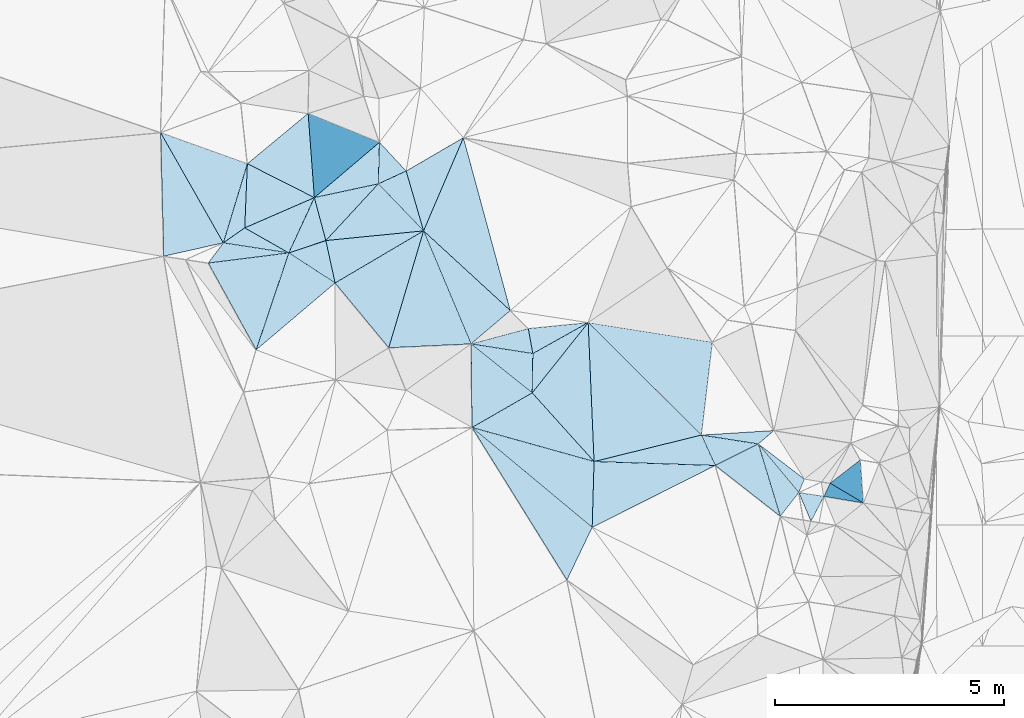
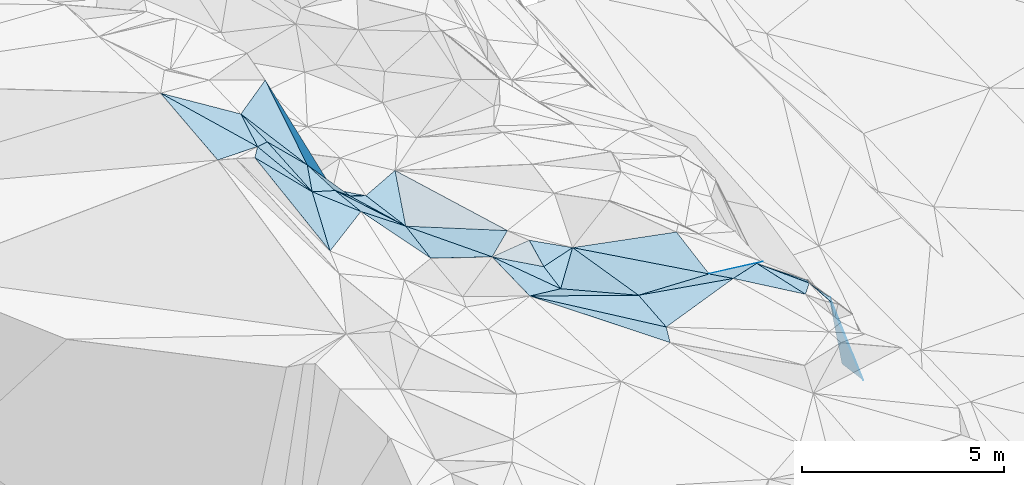
# One storey, part 132 of 275: 45 plates.
"""IFC2X3 building model written with IfcOpenShell, lengths in millimetres."""

from ifc_helpers import new_model, si_unit, frame, origin_with_axes, place, context, subcontext, project, spatial, polyline, outline, extrude, material, type_object, element, save


model = new_model("IFC2X3")

# Units and contexts
model_context = context("Model", 3, precision=1e-05, world=origin_with_axes())
body_context = subcontext(model_context, "Body", "Model", "MODEL_VIEW")
ifc_project = project(units=[si_unit("LENGTHUNIT", "METRE", prefix="MILLI"), si_unit("AREAUNIT", "SQUARE_METRE"), si_unit("VOLUMEUNIT", "CUBIC_METRE"), si_unit("MASSUNIT", "GRAM", prefix="KILO"), si_unit("TIMEUNIT", "SECOND"), si_unit("PLANEANGLEUNIT", "RADIAN"), si_unit("SOLIDANGLEUNIT", "STERADIAN"), si_unit("THERMODYNAMICTEMPERATUREUNIT", "DEGREE_CELSIUS"), si_unit("LUMINOUSINTENSITYUNIT", "LUMEN")], contexts=[model_context])

# Site, building, storey
site_placement = place(None, origin_with_axes())
site = spatial("IfcSite", under=ifc_project, at=site_placement, CompositionType="ELEMENT")
building_placement = place(site_placement, origin_with_axes())
building = spatial("IfcBuilding", under=site, at=building_placement, Name="Undefined", CompositionType="ELEMENT")
storey_placement = place(building_placement, origin_with_axes())
storey = spatial("IfcBuildingStorey", under=building, at=storey_placement, Name="Undefined", CompositionType="ELEMENT", Elevation=0.0)

# Plates
ifc_material = material()
plate_type_1 = type_object("IfcPlateType", PredefinedType="NOTDEFINED")
plate_1_placement = place(storey_placement, frame((-101077.108346665, 115262.786715546, 51369.5086691945), z_axis=(-0.182962284867591, 0.031444038574447, -0.982616952201701), x_axis=(-0.777096045290912, 0.607602228852694, 0.164137953826845)))
element("IfcPlate", 1, at=plate_1_placement, inside=storey, type_object=plate_type_1, material=ifc_material, Name="00", context=body_context, shape_type="SweptSolid", body=[
    extrude(outline(polyline([(0.0, 0.0), (1827.73083496094, 7.90896592661738e-09), (1356.65490722656, 953.2509765625), (0.0, 0.0)])), frame((-8.85201319254618e-08, 2.18876761149539e-07, -0.5000001331573), z_axis=(0.0, 0.0, 1.0), x_axis=(1.0, 0.0, 0.0)), (0.0, 0.0, 1.0), 1.0),
])
plate_type_2 = type_object("IfcPlateType", PredefinedType="NOTDEFINED")
plate_2_placement = place(storey_placement, frame((-107838.171604734, 119030.818476236, 52579.5627187452), z_axis=(-0.483887104262502, 0.0327773503198025, -0.874516389574525), x_axis=(0.710391993336381, -0.568875633902452, -0.414395618890508)))
element("IfcPlate", 2, at=plate_2_placement, inside=storey, type_object=plate_type_2, material=ifc_material, Name="00", context=body_context, shape_type="SweptSolid", body=[
    extrude(outline(polyline([(0.0, 0.0), (1882.25927734375, -1.17724994197488e-08), (1087.62915039063, 1471.14343261719), (0.0, 0.0)])), frame((-8.85201319254618e-08, 2.18876761149539e-07, -0.5000001331573), z_axis=(0.0, 0.0, 1.0), x_axis=(1.0, 0.0, 0.0)), (0.0, 0.0, 1.0), 1.0),
])
plate_type_3 = type_object("IfcPlateType", PredefinedType="NOTDEFINED")
plate_3_placement = place(storey_placement, frame((-111012.926565, 121290.092607468, 54319.6722247281), z_axis=(-0.755192114331639, 0.000595253950786495, -0.655503254091116), x_axis=(-0.247513106414454, 0.925712610213253, 0.285995498994711)))
element("IfcPlate", 3, at=plate_3_placement, inside=storey, type_object=plate_type_3, material=ifc_material, Name="00", context=body_context, shape_type="SweptSolid", body=[
    extrude(outline(polyline([(0.0, 0.0), (1014.001953125, -4.00177668780088e-09), (486.093719482422, 2087.46557617188), (0.0, 0.0)])), frame((-8.85201319254618e-08, 2.18876761149539e-07, -0.5000001331573), z_axis=(0.0, 0.0, 1.0), x_axis=(1.0, 0.0, 0.0)), (0.0, 0.0, 1.0), 1.0),
])
plate_type_4 = type_object("IfcPlateType", PredefinedType="NOTDEFINED")
plate_4_placement = place(storey_placement, frame((-109840.872069858, 123437.121596076, 52649.5663538302), z_axis=(-0.378087920472236, -0.323940930708108, -0.867243793754066), x_axis=(0.68078087842298, -0.732115498970907, -0.023330060870378)))
element("IfcPlate", 4, at=plate_4_placement, inside=storey, type_object=plate_type_4, material=ifc_material, Name="00", context=body_context, shape_type="SweptSolid", body=[
    extrude(outline(polyline([(0.0, 0.0), (857.263061523438, -2.80988388112746e-09), (639.24365234375, 733.7353515625), (0.0, 0.0)])), frame((-8.85201319254618e-08, 2.18876761149539e-07, -0.5000001331573), z_axis=(0.0, 0.0, 1.0), x_axis=(1.0, 0.0, 0.0)), (0.0, 0.0, 1.0), 1.0),
])
plate_type_5 = type_object("IfcPlateType", PredefinedType="NOTDEFINED")
plate_5_placement = place(storey_placement, frame((-102497.358780842, 116373.178783686, 51669.5163870019), z_axis=(-0.0390057522688102, -0.251076131078174, -0.967181124553597), x_axis=(-0.407169839184442, 0.887909828823298, -0.214076757116452)))
element("IfcPlate", 5, at=plate_5_placement, inside=storey, type_object=plate_type_5, material=ifc_material, Name="00", context=body_context, shape_type="SweptSolid", body=[
    extrude(outline(polyline([(0.0, 0.0), (747.3955078125, 3.07773007079959e-09), (69.0397567749023, 1061.05297851563), (0.0, 0.0)])), frame((-8.85201319254618e-08, 2.18876761149539e-07, -0.5000001331573), z_axis=(0.0, 0.0, 1.0), x_axis=(1.0, 0.0, 0.0)), (0.0, 0.0, 1.0), 1.0),
])
plate_type_6 = type_object("IfcPlateType", PredefinedType="NOTDEFINED")
plate_6_placement = place(storey_placement, frame((-108875.928222618, 121502.237612127, 52369.5129660473), z_axis=(-0.176136638375276, 0.142329663975436, -0.974021638042244), x_axis=(-0.274953401369409, 0.942994209059172, 0.187516795931085)))
element("IfcPlate", 6, at=plate_6_placement, inside=storey, type_object=plate_type_6, material=ifc_material, Name="00", context=body_context, shape_type="SweptSolid", body=[
    extrude(outline(polyline([(0.0, 0.0), (1386.54248046875, -7.97444954514503e-09), (1706.76342773438, 1418.11791992188), (0.0, 0.0)])), frame((-8.85201319254618e-08, 2.18876761149539e-07, -0.5000001331573), z_axis=(0.0, 0.0, 1.0), x_axis=(1.0, 0.0, 0.0)), (0.0, 0.0, 1.0), 1.0),
])
plate_type_7 = type_object("IfcPlateType", PredefinedType="NOTDEFINED")
plate_7_placement = place(storey_placement, frame((-99259.4544158004, 115552.595926129, 47959.8654283278), z_axis=(-0.959563111316431, -0.0826057911588249, -0.269100201909539), x_axis=(-0.279513631256925, 0.166423466974687, 0.945608459977856)))
element("IfcPlate", 7, at=plate_7_placement, inside=storey, type_object=plate_type_7, material=ifc_material, Name="00", context=body_context, shape_type="SweptSolid", body=[
    extrude(outline(polyline([(0.0, 0.0), (2601.49951171875, 7.15954229235649e-09), (128.502807617188, 938.342712402344), (0.0, 0.0)])), frame((-8.85201319254618e-08, 2.18876761149539e-07, -0.5000001331573), z_axis=(0.0, 0.0, 1.0), x_axis=(1.0, 0.0, 0.0)), (0.0, 0.0, 1.0), 1.0),
])
plate_type_8 = type_object("IfcPlateType", PredefinedType="NOTDEFINED")
plate_8_placement = place(storey_placement, frame((-108876.102537069, 121502.174567281, 52369.5744315217), z_axis=(-0.524768448998923, 0.0162321718583535, -0.851090237008994), x_axis=(-0.634731658565593, 0.658754098098725, 0.403929152021375)))
element("IfcPlate", 8, at=plate_8_placement, inside=storey, type_object=plate_type_8, material=ifc_material, Name="00", context=body_context, shape_type="SweptSolid", body=[
    extrude(outline(polyline([(0.0, 0.0), (1559.67944335938, 6.81393430568278e-09), (1208.3251953125, 680.036926269531), (0.0, 0.0)])), frame((-8.85201319254618e-08, 2.18876761149539e-07, -0.5000001331573), z_axis=(0.0, 0.0, 1.0), x_axis=(1.0, 0.0, 0.0)), (0.0, 0.0, 1.0), 1.0),
])
plate_type_9 = type_object("IfcPlateType", PredefinedType="NOTDEFINED")
plate_9_placement = place(storey_placement, frame((-111263.953019028, 122228.912316033, 54609.7810191982), z_axis=(-0.850555645167409, 0.291181920721333, -0.43791344295293), x_axis=(-0.0575177623576094, 0.77621183591715, 0.627843047899315)))
element("IfcPlate", 9, at=plate_9_placement, inside=storey, type_object=plate_type_9, material=ifc_material, Name="00", context=body_context, shape_type="SweptSolid", body=[
    extrude(outline(polyline([(0.0, 0.0), (2373.20458984375, -5.17320586368442e-09), (-374.346160888672, 2680.75830078125), (0.0, 0.0)])), frame((-8.85201319254618e-08, 2.18876761149539e-07, -0.5000001331573), z_axis=(0.0, 0.0, 1.0), x_axis=(1.0, 0.0, 0.0)), (0.0, 0.0, 1.0), 1.0),
])
plate_type_10 = type_object("IfcPlateType", PredefinedType="NOTDEFINED")
plate_10_placement = place(storey_placement, frame((-111263.769573413, 122228.835583972, 54609.5677979019), z_axis=(-0.483651953007309, 0.137723123119735, -0.864357061468443), x_axis=(0.247513106421055, -0.925712610211206, -0.285995498995624)))
element("IfcPlate", 10, at=plate_10_placement, inside=storey, type_object=plate_type_10, material=ifc_material, Name="00", context=body_context, shape_type="SweptSolid", body=[
    extrude(outline(polyline([(0.0, 0.0), (1014.001953125, -4.00177668780088e-09), (946.743713378906, 944.709655761719), (0.0, 0.0)])), frame((-8.85201319254618e-08, 2.18876761149539e-07, -0.5000001331573), z_axis=(0.0, 0.0, 1.0), x_axis=(1.0, 0.0, 0.0)), (0.0, 0.0, 1.0), 1.0),
])
plate_type_11 = type_object("IfcPlateType", PredefinedType="NOTDEFINED")
plate_11_placement = place(storey_placement, frame((-111822.486857944, 121019.681198865, 54729.5450177041), z_axis=(-0.348634186114581, 0.224736675516416, -0.909916276890381), x_axis=(0.763235014934355, -0.495400192584353, -0.41479026165707)))
element("IfcPlate", 11, at=plate_11_placement, inside=storey, type_object=plate_type_11, material=ifc_material, Name="00", context=body_context, shape_type="SweptSolid", body=[
    extrude(outline(polyline([(0.0, 0.0), (1325.97131347656, -2.99769453704357e-09), (608.912109375, 2166.63940429688), (0.0, 0.0)])), frame((-8.85201319254618e-08, 2.18876761149539e-07, -0.5000001331573), z_axis=(0.0, 0.0, 1.0), x_axis=(1.0, 0.0, 0.0)), (0.0, 0.0, 1.0), 1.0),
])
plate_type_12 = type_object("IfcPlateType", PredefinedType="NOTDEFINED")
plate_12_placement = place(storey_placement, frame((-99986.5974080244, 115985.673115825, 50419.8465753162), z_axis=(-0.936355367715108, 0.170613160853396, -0.306805760530533), x_axis=(0.279513631268442, -0.166423466966174, -0.94560845997595)))
element("IfcPlate", 12, at=plate_12_placement, inside=storey, type_object=plate_type_12, material=ifc_material, Name="00", context=body_context, shape_type="SweptSolid", body=[
    extrude(outline(polyline([(0.0, 0.0), (2601.49951171875, 7.15954229235649e-09), (-225.908172607422, 336.400787353516), (0.0, 0.0)])), frame((-8.85201319254618e-08, 2.18876761149539e-07, -0.5000001331573), z_axis=(0.0, 0.0, 1.0), x_axis=(1.0, 0.0, 0.0)), (0.0, 0.0, 1.0), 1.0),
])
plate_type_13 = type_object("IfcPlateType", PredefinedType="NOTDEFINED")
plate_13_placement = place(storey_placement, frame((-101216.547858828, 117136.070342253, 51259.5964902693), z_axis=(-0.0906622442212895, -0.583583804214639, -0.806976022525533), x_axis=(-0.662741964870865, -0.569472900091666, 0.486285619837039)))
element("IfcPlate", 13, at=plate_13_placement, inside=storey, type_object=plate_type_13, material=ifc_material, Name="00", context=body_context, shape_type="SweptSolid", body=[
    extrude(outline(polyline([(0.0, 0.0), (514.101135253906, 1.93540472537279e-09), (1228.74645996094, 1036.9580078125), (0.0, 0.0)])), frame((-8.85201319254618e-08, 2.18876761149539e-07, -0.5000001331573), z_axis=(0.0, 0.0, 1.0), x_axis=(1.0, 0.0, 0.0)), (0.0, 0.0, 1.0), 1.0),
])
plate_type_14 = type_object("IfcPlateType", PredefinedType="NOTDEFINED")
plate_14_placement = place(storey_placement, frame((-109841.038873697, 123437.165809717, 52649.6690516666), z_axis=(-0.711683980102566, -0.235502547208102, -0.661849274928867), x_axis=(-0.0258288257508461, -0.932725581802169, 0.359660757954129)))
element("IfcPlate", 14, at=plate_14_placement, inside=storey, type_object=plate_type_14, material=ifc_material, Name="00", context=body_context, shape_type="SweptSolid", body=[
    extrude(outline(polyline([(0.0, 0.0), (973.139221191406, -5.70435076951981e-09), (1868.90002441406, 1958.01245117188), (0.0, 0.0)])), frame((-8.85201319254618e-08, 2.18876761149539e-07, -0.5000001331573), z_axis=(0.0, 0.0, 1.0), x_axis=(1.0, 0.0, 0.0)), (0.0, 0.0, 1.0), 1.0),
])
plate_type_15 = type_object("IfcPlateType", PredefinedType="NOTDEFINED")
plate_15_placement = place(storey_placement, frame((-110810.514957261, 120362.699129017, 54179.5564247159), z_axis=(-0.460354447754996, 0.0335138894185833, -0.88710236255363), x_axis=(-0.763235014935772, 0.495400192582214, 0.414790261657018)))
element("IfcPlate", 15, at=plate_15_placement, inside=storey, type_object=plate_type_15, material=ifc_material, Name="00", context=body_context, shape_type="SweptSolid", body=[
    extrude(outline(polyline([(0.0, 0.0), (1325.97131347656, -2.99769453704357e-09), (671.884826660156, 684.96044921875), (0.0, 0.0)])), frame((-8.85201319254618e-08, 2.18876761149539e-07, -0.5000001331573), z_axis=(0.0, 0.0, 1.0), x_axis=(1.0, 0.0, 0.0)), (0.0, 0.0, 1.0), 1.0),
])
plate_16_placement = place(storey_placement, frame((-107838.131307046, 119030.878856185, 52579.5489235069), z_axis=(-0.403271693237357, 0.1535448908215, -0.902106372849726), x_axis=(0.894788751502755, -0.140286585797393, -0.423878241986365)))
element("IfcPlate", 16, at=plate_16_placement, inside=storey, type_object=plate_type_15, material=ifc_material, Name="00", context=body_context, shape_type="SweptSolid", body=[
    extrude(outline(polyline([(0.0, 0.0), (1509.86755371094, -5.5733835324645e-09), (1677.29943847656, 854.146667480469), (0.0, 0.0)])), frame((-8.85201319254618e-08, 2.18876761149539e-07, -0.5000001331573), z_axis=(0.0, 0.0, 1.0), x_axis=(1.0, 0.0, 0.0)), (0.0, 0.0, 1.0), 1.0),
])
plate_type_16 = type_object("IfcPlateType", PredefinedType="NOTDEFINED")
plate_17_placement = place(storey_placement, frame((-113253.855158895, 121239.878515028, 56459.6963707998), z_axis=(-0.667762325774241, 0.430568968177168, -0.607209881276174), x_axis=(0.634390816175151, -0.0975580018185462, -0.766831616871525)))
element("IfcPlate", 17, at=plate_17_placement, inside=storey, type_object=plate_type_16, material=ifc_material, Name="00", context=body_context, shape_type="SweptSolid", body=[
    extrude(outline(polyline([(0.0, 0.0), (2256.03637695313, -1.02445483207703e-08), (-204.562301635742, 513.764770507813), (0.0, 0.0)])), frame((-8.85201319254618e-08, 2.18876761149539e-07, -0.5000001331573), z_axis=(0.0, 0.0, 1.0), x_axis=(1.0, 0.0, 0.0)), (0.0, 0.0, 1.0), 1.0),
])
plate_type_17 = type_object("IfcPlateType", PredefinedType="NOTDEFINED")
plate_18_placement = place(storey_placement, frame((-102801.726887501, 117036.777690168, 51509.5271571889), z_axis=(-0.141424019289442, -0.292849055725468, -0.945641939281841), x_axis=(0.407169839185727, -0.887909828824076, 0.214076757110786)))
element("IfcPlate", 18, at=plate_18_placement, inside=storey, type_object=plate_type_17, material=ifc_material, Name="00", context=body_context, shape_type="SweptSolid", body=[
    extrude(outline(polyline([(0.0, 0.0), (747.3955078125, 3.07773007079959e-09), (-328.607818603516, 2452.2880859375), (0.0, 0.0)])), frame((-8.85201319254618e-08, 2.18876761149539e-07, -0.5000001331573), z_axis=(0.0, 0.0, 1.0), x_axis=(1.0, 0.0, 0.0)), (0.0, 0.0, 1.0), 1.0),
])
plate_type_18 = type_object("IfcPlateType", PredefinedType="NOTDEFINED")
plate_19_placement = place(storey_placement, frame((-111822.690205888, 121019.714208473, 54729.7063181024), z_axis=(-0.755326613196804, 0.290760610089798, -0.587315907341913), x_axis=(-0.514442984147752, 0.292129874820265, 0.806231078722876)))
element("IfcPlate", 19, at=plate_19_placement, inside=storey, type_object=plate_type_18, material=ifc_material, Name="00", context=body_context, shape_type="SweptSolid", body=[
    extrude(outline(polyline([(0.0, 0.0), (1872.91223144531, -7.48696038499475e-09), (-30.9678153991699, 1337.10168457031), (0.0, 0.0)])), frame((-8.85201319254618e-08, 2.18876761149539e-07, -0.5000001331573), z_axis=(0.0, 0.0, 1.0), x_axis=(1.0, 0.0, 0.0)), (0.0, 0.0, 1.0), 1.0),
])
plate_type_19 = type_object("IfcPlateType", PredefinedType="NOTDEFINED")
plate_20_placement = place(storey_placement, frame((-107838.054867006, 119031.116260068, 52579.6317113716), z_axis=(-0.250394181323223, 0.628351621189602, -0.736530375550033), x_axis=(0.960472364045447, 0.2568070213183, -0.107438315821557)))
element("IfcPlate", 20, at=plate_20_placement, inside=storey, type_object=plate_type_19, material=ifc_material, Name="00", context=body_context, shape_type="SweptSolid", body=[
    extrude(outline(polyline([(0.0, 0.0), (1303.0732421875, 9.22591425478458e-09), (1311.97534179688, 747.275573730469), (0.0, 0.0)])), frame((-8.85201319254618e-08, 2.18876761149539e-07, -0.5000001331573), z_axis=(0.0, 0.0, 1.0), x_axis=(1.0, 0.0, 0.0)), (0.0, 0.0, 1.0), 1.0),
])
plate_type_20 = type_object("IfcPlateType", PredefinedType="NOTDEFINED")
plate_21_placement = place(storey_placement, frame((-100672.253206617, 115780.82456089, 51249.6551102101), z_axis=(-0.723960092151855, 0.0121237250448085, -0.689735311741044), x_axis=(0.685064624005919, -0.104829660824563, -0.720900272677876)))
element("IfcPlate", 21, at=plate_21_placement, inside=storey, type_object=plate_type_20, material=ifc_material, Name="00", context=body_context, shape_type="SweptSolid", body=[
    extrude(outline(polyline([(0.0, 0.0), (804.549560546875, 4.40923031419516e-09), (456.777313232422, 581.338500976563), (0.0, 0.0)])), frame((-8.85201319254618e-08, 2.18876761149539e-07, -0.5000001331573), z_axis=(0.0, 0.0, 1.0), x_axis=(1.0, 0.0, 0.0)), (0.0, 0.0, 1.0), 1.0),
])
plate_type_21 = type_object("IfcPlateType", PredefinedType="NOTDEFINED")
plate_22_placement = place(storey_placement, frame((-112786.134547558, 121566.956301525, 56239.7066840931), z_axis=(-0.630961014352054, 0.507747996676757, -0.586583472524215), x_axis=(0.514442984146051, -0.292129874823505, -0.806231078722787)))
element("IfcPlate", 22, at=plate_22_placement, inside=storey, type_object=plate_type_21, material=ifc_material, Name="00", context=body_context, shape_type="SweptSolid", body=[
    extrude(outline(polyline([(0.0, 0.0), (1872.91223144531, -7.48696038499475e-09), (-322.439025878906, 519.743286132813), (0.0, 0.0)])), frame((-8.85201319254618e-08, 2.18876761149539e-07, -0.5000001331573), z_axis=(0.0, 0.0, 1.0), x_axis=(1.0, 0.0, 0.0)), (0.0, 0.0, 1.0), 1.0),
])
plate_type_22 = type_object("IfcPlateType", PredefinedType="NOTDEFINED")
plate_23_placement = place(storey_placement, frame((-113253.732094833, 121239.661725933, 56459.5465959952), z_axis=(-0.421637104836193, -0.00301130101394723, -0.906759661592617), x_axis=(-0.482310612401895, 0.847545564984383, 0.221456515911843)))
element("IfcPlate", 23, at=plate_23_placement, inside=storey, type_object=plate_type_22, material=ifc_material, Name="00", context=body_context, shape_type="SweptSolid", body=[
    extrude(outline(polyline([(0.0, 0.0), (2844.80224609375, -3.39059624820948e-09), (1157.65515136719, 1411.25280761719), (0.0, 0.0)])), frame((-8.85201319254618e-08, 2.18876761149539e-07, -0.5000001331573), z_axis=(0.0, 0.0, 1.0), x_axis=(1.0, 0.0, 0.0)), (0.0, 0.0, 1.0), 1.0),
])
plate_type_23 = type_object("IfcPlateType", PredefinedType="NOTDEFINED")
plate_24_placement = place(storey_placement, frame((-106500.933473571, 117960.109875183, 51799.5282927258), z_axis=(-0.291452810281898, 0.158464479438118, -0.943368574913957), x_axis=(0.0159358196583348, 0.986850990494333, 0.160845180879539)))
element("IfcPlate", 24, at=plate_24_placement, inside=storey, type_object=plate_type_23, material=ifc_material, Name="00", context=body_context, shape_type="SweptSolid", body=[
    extrude(outline(polyline([(0.0, 0.0), (870.402221679688, -5.36965671926737e-09), (1515.85095214844, 1253.91223144531), (0.0, 0.0)])), frame((-8.85201319254618e-08, 2.18876761149539e-07, -0.5000001331573), z_axis=(0.0, 0.0, 1.0), x_axis=(1.0, 0.0, 0.0)), (0.0, 0.0, 1.0), 1.0),
])
plate_type_24 = type_object("IfcPlateType", PredefinedType="NOTDEFINED")
plate_25_placement = place(storey_placement, frame((-105148.374526107, 116458.533959916, 52039.5547385356), z_axis=(-0.258018992449383, -0.374803490783426, -0.890476581854887), x_axis=(-0.950227265659472, 0.265038310612979, 0.163776791715864)))
element("IfcPlate", 25, at=plate_25_placement, inside=storey, type_object=plate_type_24, material=ifc_material, Name="00", context=body_context, shape_type="SweptSolid", body=[
    extrude(outline(polyline([(0.0, 0.0), (2808.70068359375, -7.66885932534933e-09), (1643.82055664063, 1199.48071289063), (0.0, 0.0)])), frame((-8.85201319254618e-08, 2.18876761149539e-07, -0.5000001331573), z_axis=(0.0, 0.0, 1.0), x_axis=(1.0, 0.0, 0.0)), (0.0, 0.0, 1.0), 1.0),
])
plate_type_25 = type_object("IfcPlateType", PredefinedType="NOTDEFINED")
plate_26_placement = place(storey_placement, frame((-109866.144839111, 122529.522337406, 52999.6322162612), z_axis=(-0.653514896361111, -0.17868334308478, -0.735520593279463), x_axis=(0.634731658556593, -0.658754098106939, -0.403929152022121)))
element("IfcPlate", 26, at=plate_26_placement, inside=storey, type_object=plate_type_25, material=ifc_material, Name="00", context=body_context, shape_type="SweptSolid", body=[
    extrude(outline(polyline([(0.0, 0.0), (1559.67944335938, 6.81393430568278e-09), (-444.514404296875, 2096.71337890625), (0.0, 0.0)])), frame((-8.85201319254618e-08, 2.18876761149539e-07, -0.5000001331573), z_axis=(0.0, 0.0, 1.0), x_axis=(1.0, 0.0, 0.0)), (0.0, 0.0, 1.0), 1.0),
])
plate_type_26 = type_object("IfcPlateType", PredefinedType="NOTDEFINED")
plate_27_placement = place(storey_placement, frame((-105189.723482231, 115019.065036502, 51969.5053336495), z_axis=(-0.13640324430212, 0.0520243065843487, -0.989286422866641), x_axis=(0.0287173387102839, 0.998408109039329, 0.0485444359521248)))
element("IfcPlate", 27, at=plate_27_placement, inside=storey, type_object=plate_type_26, material=ifc_material, Name="00", context=body_context, shape_type="SweptSolid", body=[
    extrude(outline(polyline([(0.0, 0.0), (1441.97778320313, 6.51925802230835e-09), (1414.8623046875, 2677.82836914063), (0.0, 0.0)])), frame((-8.85201319254618e-08, 2.18876761149539e-07, -0.5000001331573), z_axis=(0.0, 0.0, 1.0), x_axis=(1.0, 0.0, 0.0)), (0.0, 0.0, 1.0), 1.0),
])
plate_type_27 = type_object("IfcPlateType", PredefinedType="NOTDEFINED")
plate_28_placement = place(storey_placement, frame((-101557.464163736, 116843.494897298, 51509.5760040136), z_axis=(-0.490446821590892, -0.201114466600203, -0.847947455043948), x_axis=(0.757948783849373, -0.578637171497662, -0.301152228652623)))
element("IfcPlate", 28, at=plate_28_placement, inside=storey, type_object=plate_type_27, material=ifc_material, Name="00", context=body_context, shape_type="SweptSolid", body=[
    extrude(outline(polyline([(0.0, 0.0), (1328.23193359375, 5.56610757485032e-09), (1364.294921875, 345.83154296875), (0.0, 0.0)])), frame((-8.85201319254618e-08, 2.18876761149539e-07, -0.5000001331573), z_axis=(0.0, 0.0, 1.0), x_axis=(1.0, 0.0, 0.0)), (0.0, 0.0, 1.0), 1.0),
])
plate_type_28 = type_object("IfcPlateType", PredefinedType="NOTDEFINED")
plate_29_placement = place(storey_placement, frame((-101557.360360929, 116843.594965777, 51509.5203969151), z_axis=(-0.282857275044419, -0.00097799393680062, -0.959161511676894), x_axis=(0.629032056247361, -0.755111097825613, -0.184731973826448)))
element("IfcPlate", 29, at=plate_29_placement, inside=storey, type_object=plate_type_28, material=ifc_material, Name="00", context=body_context, shape_type="SweptSolid", body=[
    extrude(outline(polyline([(0.0, 0.0), (1407.44445800781, -3.83806764148176e-10), (1521.623046875, 658.682983398438), (0.0, 0.0)])), frame((-8.85201319254618e-08, 2.18876761149539e-07, -0.5000001331573), z_axis=(0.0, 0.0, 1.0), x_axis=(1.0, 0.0, 0.0)), (0.0, 0.0, 1.0), 1.0),
])
plate_type_29 = type_object("IfcPlateType", PredefinedType="NOTDEFINED")
plate_30_placement = place(storey_placement, frame((-111012.884869158, 121290.074900912, 54319.6300199189), z_axis=(-0.671801524958065, -0.0348213517466167, -0.739912281643275), x_axis=(0.736664764137897, 0.073115973196288, -0.672293893874708)))
element("IfcPlate", 30, at=plate_30_placement, inside=storey, type_object=plate_type_29, material=ifc_material, Name="00", context=body_context, shape_type="SweptSolid", body=[
    extrude(outline(polyline([(0.0, 0.0), (2900.51708984375, -4.48198989033699e-09), (175.313568115234, 943.32666015625), (0.0, 0.0)])), frame((-8.85201319254618e-08, 2.18876761149539e-07, -0.5000001331573), z_axis=(0.0, 0.0, 1.0), x_axis=(1.0, 0.0, 0.0)), (0.0, 0.0, 1.0), 1.0),
])
plate_type_30 = type_object("IfcPlateType", PredefinedType="NOTDEFINED")
plate_31_placement = place(storey_placement, frame((-106979.472742358, 119760.171042724, 52629.5050787188), z_axis=(0.14230262775761, 0.00717604990533867, -0.989797184498438), x_axis=(-0.732707058313701, 0.67308836888605, -0.100461009190632)))
element("IfcPlate", 31, at=plate_31_placement, inside=storey, type_object=plate_type_30, material=ifc_material, Name="00", context=body_context, shape_type="SweptSolid", body=[
    extrude(outline(polyline([(0.0, 0.0), (2588.06884765625, -1.41735654324293e-08), (3306.21044921875, 2099.61254882813), (0.0, 0.0)])), frame((-8.85201319254618e-08, 2.18876761149539e-07, -0.5000001331573), z_axis=(0.0, 0.0, 1.0), x_axis=(1.0, 0.0, 0.0)), (0.0, 0.0, 1.0), 1.0),
])
plate_type_31 = type_object("IfcPlateType", PredefinedType="NOTDEFINED")
plate_32_placement = place(storey_placement, frame((-112728.447827011, 122969.79950964, 56209.5472715744), z_axis=(-0.424536895075349, -0.00193566897102611, -0.905408569600165), x_axis=(-0.0409963866876121, -0.99893098611784, 0.0213584000383737)))
element("IfcPlate", 32, at=plate_32_placement, inside=storey, type_object=plate_type_31, material=ifc_material, Name="00", context=body_context, shape_type="SweptSolid", body=[
    extrude(outline(polyline([(0.0, 0.0), (1404.599609375, -6.81029632687569e-09), (1755.162109375, 501.204467773438), (0.0, 0.0)])), frame((-8.85201319254618e-08, 2.18876761149539e-07, -0.5000001331573), z_axis=(0.0, 0.0, 1.0), x_axis=(1.0, 0.0, 0.0)), (0.0, 0.0, 1.0), 1.0),
])
plate_type_32 = type_object("IfcPlateType", PredefinedType="NOTDEFINED")
plate_33_placement = place(storey_placement, frame((-107817.31670611, 117203.045906602, 52499.5371733036), z_axis=(-0.334269579077012, -0.177519239186027, -0.925608323332548), x_axis=(0.759921630040015, -0.631682257646289, -0.153286142792535)))
element("IfcPlate", 33, at=plate_33_placement, inside=storey, type_object=plate_type_32, material=ifc_material, Name="00", context=body_context, shape_type="SweptSolid", body=[
    extrude(outline(polyline([(0.0, 0.0), (3457.5859375, 1.93649611901492e-08), (3701.33984375, 1321.65954589844), (0.0, 0.0)])), frame((-8.85201319254618e-08, 2.18876761149539e-07, -0.5000001331573), z_axis=(0.0, 0.0, 1.0), x_axis=(1.0, 0.0, 0.0)), (0.0, 0.0, 1.0), 1.0),
])
plate_type_33 = type_object("IfcPlateType", PredefinedType="NOTDEFINED")
plate_34_placement = place(storey_placement, frame((-107817.227264928, 117203.160883282, 52499.5067463382), z_axis=(-0.155396918125258, 0.0524331793175663, -0.986459608673272), x_axis=(0.950227265659251, -0.265038310612147, -0.163776791718494)))
element("IfcPlate", 34, at=plate_34_placement, inside=storey, type_object=plate_type_33, material=ifc_material, Name="00", context=body_context, shape_type="SweptSolid", body=[
    extrude(outline(polyline([(0.0, 0.0), (2808.70068359375, -7.66885932534933e-09), (3162.38745117188, 1397.92907714844), (0.0, 0.0)])), frame((-8.85201319254618e-08, 2.18876761149539e-07, -0.5000001331573), z_axis=(0.0, 0.0, 1.0), x_axis=(1.0, 0.0, 0.0)), (0.0, 0.0, 1.0), 1.0),
])
plate_type_34 = type_object("IfcPlateType", PredefinedType="NOTDEFINED")
plate_35_placement = place(storey_placement, frame((-105277.418738433, 119495.819258322, 51679.5129430607), z_axis=(-0.189568492238451, -0.123514607866024, -0.974067722693932), x_axis=(0.708656748214083, -0.703873280812307, -0.0486622828190535)))
element("IfcPlate", 35, at=plate_35_placement, inside=storey, type_object=plate_type_34, material=ifc_material, Name="00", context=body_context, shape_type="SweptSolid", body=[
    extrude(outline(polyline([(0.0, 0.0), (3493.46533203125, 9.10222297534347e-09), (2211.7294921875, 2116.330078125), (0.0, 0.0)])), frame((-8.85201319254618e-08, 2.18876761149539e-07, -0.5000001331573), z_axis=(0.0, 0.0, 1.0), x_axis=(1.0, 0.0, 0.0)), (0.0, 0.0, 1.0), 1.0),
])
plate_type_35 = type_object("IfcPlateType", PredefinedType="NOTDEFINED")
plate_36_placement = place(storey_placement, frame((-105148.22164282, 116458.663576818, 52039.5039022096), z_axis=(0.0477677272128588, -0.115571205233532, -0.992149958805516), x_axis=(-0.664665990472995, 0.737773069099999, -0.117940746221656)))
element("IfcPlate", 36, at=plate_36_placement, inside=storey, type_object=plate_type_35, material=ifc_material, Name="00", context=body_context, shape_type="SweptSolid", body=[
    extrude(outline(polyline([(0.0, 0.0), (2034.92016601563, -1.03455022326671e-09), (2368.9873046875, 1938.68493652344), (0.0, 0.0)])), frame((-8.85201319254618e-08, 2.18876761149539e-07, -0.5000001331573), z_axis=(0.0, 0.0, 1.0), x_axis=(1.0, 0.0, 0.0)), (0.0, 0.0, 1.0), 1.0),
])
plate_type_36 = type_object("IfcPlateType", PredefinedType="NOTDEFINED")
plate_37_placement = place(storey_placement, frame((-106487.146615904, 118819.264362768, 51939.6522192972), z_axis=(-0.458893224825946, 0.552879261143791, -0.695515298757648), x_axis=(-0.133069461388512, 0.731207867159916, 0.669049754090993)))
element("IfcPlate", 37, at=plate_37_placement, inside=storey, type_object=plate_type_36, material=ifc_material, Name="00", context=body_context, shape_type="SweptSolid", body=[
    extrude(outline(polyline([(0.0, 0.0), (747.328552246094, -4.88944351673126e-09), (160.036697387695, 1401.173828125), (0.0, 0.0)])), frame((-8.85201319254618e-08, 2.18876761149539e-07, -0.5000001331573), z_axis=(0.0, 0.0, 1.0), x_axis=(1.0, 0.0, 0.0)), (0.0, 0.0, 1.0), 1.0),
])
plate_type_37 = type_object("IfcPlateType", PredefinedType="NOTDEFINED")
plate_38_placement = place(storey_placement, frame((-108875.999433299, 121502.060306437, 52369.5380680451), z_axis=(-0.318579233231024, -0.212295009894406, -0.923817136086936), x_axis=(0.386029757281839, -0.919173866928996, 0.0781052421270237)))
element("IfcPlate", 38, at=plate_38_placement, inside=storey, type_object=plate_type_37, material=ifc_material, Name="00", context=body_context, shape_type="SweptSolid", body=[
    extrude(outline(polyline([(0.0, 0.0), (2688.67993164063, 1.0986695997417e-08), (2122.0078125, 1825.75537109375), (0.0, 0.0)])), frame((-8.85201319254618e-08, 2.18876761149539e-07, -0.5000001331573), z_axis=(0.0, 0.0, 1.0), x_axis=(1.0, 0.0, 0.0)), (0.0, 0.0, 1.0), 1.0),
])
plate_type_38 = type_object("IfcPlateType", PredefinedType="NOTDEFINED")
plate_39_placement = place(storey_placement, frame((-105277.365489349, 119495.873645578, 51679.5017600966), z_axis=(-0.0830634078835549, -0.01473934236026, -0.99643525733364), x_axis=(0.984613885490905, -0.155470021780945, -0.0797782478244236)))
element("IfcPlate", 39, at=plate_39_placement, inside=storey, type_object=plate_type_38, material=ifc_material, Name="00", context=body_context, shape_type="SweptSolid", body=[
    extrude(outline(polyline([(0.0, 0.0), (2757.64404296875, 5.98083715885878e-09), (2833.43334960938, 2043.515625), (0.0, 0.0)])), frame((-8.85201319254618e-08, 2.18876761149539e-07, -0.5000001331573), z_axis=(0.0, 0.0, 1.0), x_axis=(1.0, 0.0, 0.0)), (0.0, 0.0, 1.0), 1.0),
])
plate_type_39 = type_object("IfcPlateType", PredefinedType="NOTDEFINED")
plate_40_placement = place(storey_placement, frame((-109637.626557571, 118945.9752411, 53219.6282557241), z_axis=(-0.667038962310332, -0.0485127497143111, -0.743441682901297), x_axis=(-0.565371093100394, 0.682827947601147, 0.4627110556938)))
element("IfcPlate", 40, at=plate_40_placement, inside=storey, type_object=plate_type_39, material=ifc_material, Name="00", context=body_context, shape_type="SweptSolid", body=[
    extrude(outline(polyline([(0.0, 0.0), (2074.72900390625, 2.35741026699543e-09), (921.614379882813, 2643.27954101563), (0.0, 0.0)])), frame((-8.85201319254618e-08, 2.18876761149539e-07, -0.5000001331573), z_axis=(0.0, 0.0, 1.0), x_axis=(1.0, 0.0, 0.0)), (0.0, 0.0, 1.0), 1.0),
])
plate_type_40 = type_object("IfcPlateType", PredefinedType="NOTDEFINED")
plate_41_placement = place(storey_placement, frame((-112536.549785343, 118900.063439495, 54479.6755783443), z_axis=(-0.694732120768537, 0.310503013813829, -0.648795159341515), x_axis=(-0.352544322438386, 0.639240149100604, 0.683435829097581)))
element("IfcPlate", 41, at=plate_41_placement, inside=storey, type_object=plate_type_40, material=ifc_material, Name="00", context=body_context, shape_type="SweptSolid", body=[
    extrude(outline(polyline([(0.0, 0.0), (2970.2861328125, -1.88483681995422e-08), (1274.1533203125, 1855.16394042969), (0.0, 0.0)])), frame((-8.85201319254618e-08, 2.18876761149539e-07, -0.5000001331573), z_axis=(0.0, 0.0, 1.0), x_axis=(1.0, 0.0, 0.0)), (0.0, 0.0, 1.0), 1.0),
])
plate_type_41 = type_object("IfcPlateType", PredefinedType="NOTDEFINED")
plate_42_placement = place(storey_placement, frame((-108875.792351019, 121502.144273252, 52369.502761454), z_axis=(0.0956065047115478, -0.044347763430403, -0.994430828230683), x_axis=(0.732707058319223, -0.673088368880054, 0.100461009190531)))
element("IfcPlate", 42, at=plate_42_placement, inside=storey, type_object=plate_type_41, material=ifc_material, Name="00", context=body_context, shape_type="SweptSolid", body=[
    extrude(outline(polyline([(0.0, 0.0), (2588.06884765625, -1.41735654324293e-08), (2445.02783203125, 1118.40930175781), (0.0, 0.0)])), frame((-8.85201319254618e-08, 2.18876761149539e-07, -0.5000001331573), z_axis=(0.0, 0.0, 1.0), x_axis=(1.0, 0.0, 0.0)), (0.0, 0.0, 1.0), 1.0),
])
plate_type_42 = type_object("IfcPlateType", PredefinedType="NOTDEFINED")
plate_43_placement = place(storey_placement, frame((-111263.774066815, 122229.029182267, 54609.6529285662), z_axis=(-0.492638116418794, 0.524918100027031, -0.694095580244792), x_axis=(-0.638977108942168, 0.323275127675398, 0.697998170537978)))
element("IfcPlate", 43, at=plate_43_placement, inside=storey, type_object=plate_type_42, material=ifc_material, Name="00", context=body_context, shape_type="SweptSolid", body=[
    extrude(outline(polyline([(0.0, 0.0), (2292.26953125, 2.43744580075145e-09), (1722.74670410156, 1632.25109863281), (0.0, 0.0)])), frame((-8.85201319254618e-08, 2.18876761149539e-07, -0.5000001331573), z_axis=(0.0, 0.0, 1.0), x_axis=(1.0, 0.0, 0.0)), (0.0, 0.0, 1.0), 1.0),
])
plate_type_43 = type_object("IfcPlateType", PredefinedType="NOTDEFINED")
plate_44_placement = place(storey_placement, frame((-112728.602512633, 122969.808276969, 56209.6604394882), z_axis=(-0.733905018086574, 0.0156002194993903, -0.679072939807585), x_axis=(0.638977108944406, -0.323275127672276, -0.697998170537375)))
element("IfcPlate", 44, at=plate_44_placement, inside=storey, type_object=plate_type_43, material=ifc_material, Name="00", context=body_context, shape_type="SweptSolid", body=[
    extrude(outline(polyline([(0.0, 0.0), (2292.26953125, 2.43744580075145e-09), (395.852203369141, 1347.6650390625), (0.0, 0.0)])), frame((-8.85201319254618e-08, 2.18876761149539e-07, -0.5000001331573), z_axis=(0.0, 0.0, 1.0), x_axis=(1.0, 0.0, 0.0)), (0.0, 0.0, 1.0), 1.0),
])
plate_type_44 = type_object("IfcPlateType", PredefinedType="NOTDEFINED")
plate_45_placement = place(storey_placement, frame((-114625.700653921, 123650.831947927, 57089.5152013005), z_axis=(-0.202088253514861, 0.138333006502086, -0.969548511990714), x_axis=(0.482310612393694, -0.847545564991701, -0.221456515901695)))
element("IfcPlate", 45, at=plate_45_placement, inside=storey, type_object=plate_type_44, material=ifc_material, Name="00", context=body_context, shape_type="SweptSolid", body=[
    extrude(outline(polyline([(0.0, 0.0), (2844.80224609375, -3.39059624820948e-09), (2412.68090820313, 1284.47302246094), (0.0, 0.0)])), frame((-8.85201319254618e-08, 2.18876761149539e-07, -0.5000001331573), z_axis=(0.0, 0.0, 1.0), x_axis=(1.0, 0.0, 0.0)), (0.0, 0.0, 1.0), 1.0),
])

save(model, "model.ifc")
